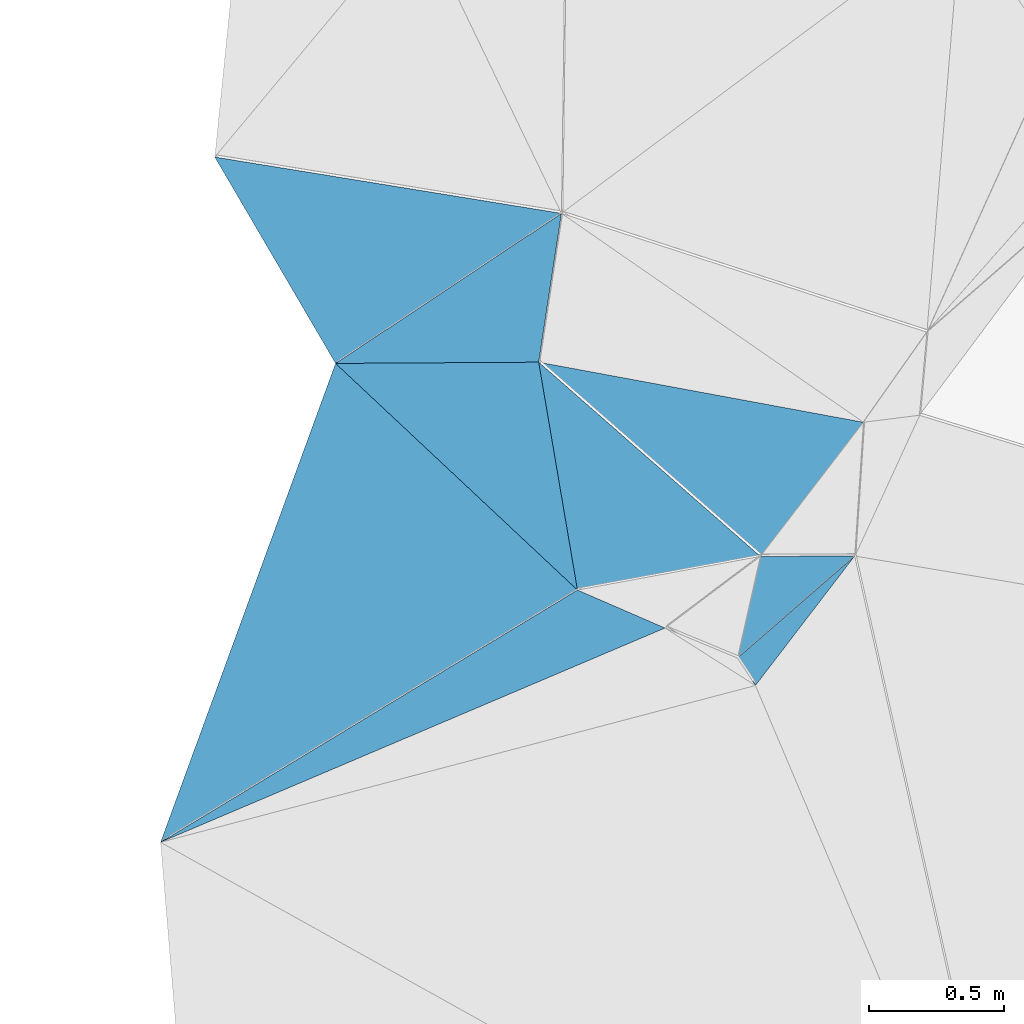
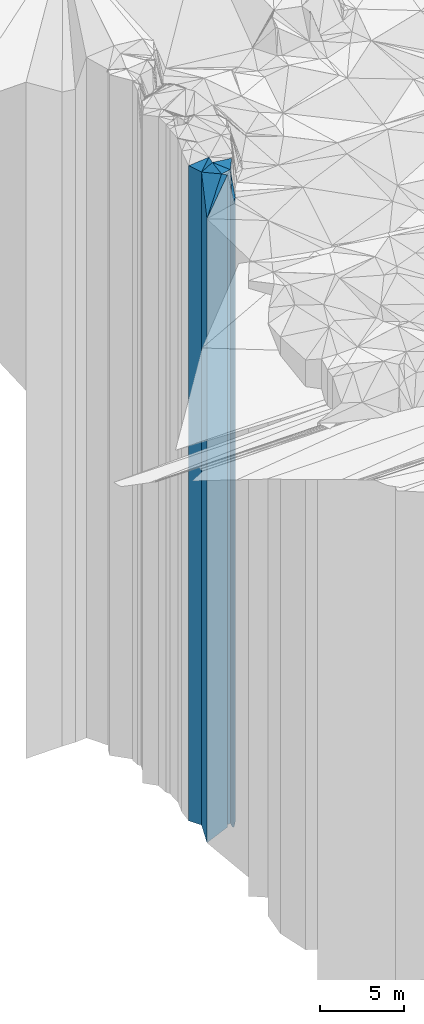
# One storey, part 219 of 275: 9 plates.
"""IFC2X3 building model written with IfcOpenShell, lengths in millimetres."""

from ifc_helpers import new_model, si_unit, frame, origin_with_axes, place, context, subcontext, project, spatial, faceted_brep, material, type_object, element, save


model = new_model("IFC2X3")

# Units and contexts
model_context = context("Model", 3, precision=1e-05, world=origin_with_axes())
body_context = subcontext(model_context, "Body", "Model", "MODEL_VIEW")
ifc_project = project(units=[si_unit("LENGTHUNIT", "METRE", prefix="MILLI"), si_unit("AREAUNIT", "SQUARE_METRE"), si_unit("VOLUMEUNIT", "CUBIC_METRE"), si_unit("MASSUNIT", "GRAM", prefix="KILO"), si_unit("TIMEUNIT", "SECOND"), si_unit("PLANEANGLEUNIT", "RADIAN"), si_unit("SOLIDANGLEUNIT", "STERADIAN"), si_unit("THERMODYNAMICTEMPERATUREUNIT", "DEGREE_CELSIUS"), si_unit("LUMINOUSINTENSITYUNIT", "LUMEN")], contexts=[model_context])

# Site, building, storey
site_placement = place(None, origin_with_axes())
site = spatial("IfcSite", under=ifc_project, at=site_placement, CompositionType="ELEMENT")
building_placement = place(site_placement, origin_with_axes())
building = spatial("IfcBuilding", under=site, at=building_placement, Name="Undefined", CompositionType="ELEMENT")
storey_placement = place(building_placement, origin_with_axes())
storey = spatial("IfcBuildingStorey", under=building, at=storey_placement, Name="Undefined", CompositionType="ELEMENT", Elevation=0.0)

# Plates
ifc_material = material()
plate_type_1 = type_object("IfcPlateType", PredefinedType="NOTDEFINED")
plate_1_placement = place(storey_placement, frame((-136499.498721579, 83557.2483316532, 30579.0), z_axis=(-0.793772278206384, 0.608215069158145, 0.0), x_axis=(0.608215069158141, 0.793772278206387, 0.0)))
element("IfcPlate", 1, at=plate_1_placement, inside=storey, type_object=plate_type_1, material=ifc_material, Name="00", context=body_context, shape_type="Brep", body=[
    faceted_brep([(-3.63797880709171e-12, -22751.0, -2.91038304567337e-11), (40.0561256408655, -22801.0, 114.871696472139), (40.0561256408655, 22751.0, 114.871696472139), (-3.63797880709171e-12, 22751.0, -2.91038304567337e-11), (604.15228271484, -22771.0, -3.43425199389458e-09), (604.15228271484, 22751.0, -3.43425199389458e-09)], [[[0, 1, 2, 3]], [[1, 4, 5, 2]], [[4, 0, 3, 5]], [[5, 3, 2]], [[4, 1, 0]]]),
])
plate_type_2 = type_object("IfcPlateType", PredefinedType="NOTDEFINED")
plate_2_placement = place(storey_placement, frame((-136481.326506082, 84035.4426128652, 30589.0), z_axis=(0.975458777497084, -0.220182136886477, 0.0), x_axis=(-0.220182136886474, -0.975458777497084, 0.0)))
element("IfcPlate", 2, at=plate_2_placement, inside=storey, type_object=plate_type_2, material=ifc_material, Name="00", context=body_context, shape_type="Brep", body=[
    faceted_brep([(7.27595761418343e-12, -24921.0, -2.91038304567337e-11), (-78.2372894287109, -22761.0, 340.409942626924), (-78.2372894287109, 22761.0, 340.409942626924), (7.27595761418343e-12, 22761.0, -2.91038304567337e-11), (386.005187988289, -22791.0, -4.36557456851006e-10), (386.005187988289, 22761.0, -4.36557456851006e-10)], [[[0, 1, 2, 3]], [[1, 4, 5, 2]], [[4, 0, 3, 5]], [[5, 3, 2]], [[4, 1, 0]]]),
])
plate_type_3 = type_object("IfcPlateType", PredefinedType="NOTDEFINED")
plate_3_placement = place(storey_placement, frame((-136099.624259448, 84532.2357236408, 31669.0), z_axis=(-0.182001300937891, -0.98329828966439, 0.0), x_axis=(-0.983298289664392, 0.182001300937881, 0.0)))
element("IfcPlate", 3, at=plate_3_placement, inside=storey, type_object=plate_type_3, material=ifc_material, Name="00", context=body_context, shape_type="Brep", body=[
    faceted_brep([(0.0, -24241.0, 0.0), (284.910186767578, -23841.0, 557.966125488281), (284.910186767578, 23841.0, 557.966125488281), (0.0, 23841.0, 0.0), (1223.19250488281, -24221.0, -1.13213900476694e-08), (1223.19250488281, 23841.0, -1.13213900476694e-08)], [[[0, 1, 2, 3]], [[1, 4, 5, 2]], [[4, 0, 3, 5]], [[5, 3, 2]], [[4, 1, 0]]]),
])
plate_type_4 = type_object("IfcPlateType", PredefinedType="NOTDEFINED")
plate_4_placement = place(storey_placement, frame((-138054.769147768, 84750.2000915425, 31639.0), z_axis=(-0.0061912420004811, 0.99998083407758, 0.0), x_axis=(0.99998083407758, 0.00619124200047754, 0.0)))
element("IfcPlate", 4, at=plate_4_placement, inside=storey, type_object=plate_type_4, material=ifc_material, Name="00", context=body_context, shape_type="Brep", body=[
    faceted_brep([(0.0, -23811.0, -1.45519152283669e-11), (840.11590576169, -24271.0, 550.640747070313), (840.11590576169, 23811.0, 550.640747070313), (0.0, 23811.0, -1.45519152283669e-11), (752.396179199219, -24251.0, 5.5297277867794e-10), (752.396179199219, 23811.0, 5.5297277867794e-10)], [[[0, 1, 2, 3]], [[1, 4, 5, 2]], [[4, 0, 3, 5]], [[5, 3, 2]], [[4, 1, 0]]]),
])
plate_type_5 = type_object("IfcPlateType", PredefinedType="NOTDEFINED")
plate_5_placement = place(storey_placement, frame((-138502.096254499, 85514.5942696885, 31639.0), z_axis=(0.863075081870162, 0.505075640924024, 0.0), x_axis=(0.505075640924028, -0.86307508187016, 0.0)))
element("IfcPlate", 5, at=plate_5_placement, inside=storey, type_object=plate_type_5, material=ifc_material, Name="00", context=body_context, shape_type="Brep", body=[
    faceted_brep([(-2.91038304567337e-11, -23971.0, -1.45519152283669e-11), (828.531311035127, -24271.0, 1002.86383056639), (828.531311035127, 23811.0, 1002.86383056639), (0.0, 23811.0, -1.45519152283669e-11), (885.663574218721, -23811.0, -8.57107806950808e-09), (885.663574218721, 23811.0, -8.57107806950808e-09)], [[[0, 1, 2, 3]], [[1, 4, 5, 2]], [[4, 0, 3, 5]], [[5, 3, 2]], [[4, 1, 0]]]),
])
plate_type_6 = type_object("IfcPlateType", PredefinedType="NOTDEFINED")
plate_6_placement = place(storey_placement, frame((-137158.801102415, 83910.8305294865, 31669.0), z_axis=(-0.1809014499919, 0.983501227955933, 0.0), x_axis=(0.983501227955934, 0.180901449991893, 0.0)))
element("IfcPlate", 6, at=plate_6_placement, inside=storey, type_object=plate_type_6, material=ifc_material, Name="00", context=body_context, shape_type="Brep", body=[
    faceted_brep([(-1.45519152283669e-11, -23841.0, -1.45519152283669e-11), (11.4685621261451, -24221.0, 856.07739257811), (11.4685621261451, 23841.0, 856.07739257811), (0.0, 23841.0, 0.0), (688.839599609375, -23841.0, 2.8085196390748e-09), (688.839599609375, 23841.0, 2.8085196390748e-09)], [[[0, 1, 2, 3]], [[1, 4, 5, 2]], [[4, 0, 3, 5]], [[5, 3, 2]], [[4, 1, 0]]]),
])
plate_type_7 = type_object("IfcPlateType", PredefinedType="NOTDEFINED")
plate_7_placement = place(storey_placement, frame((-138702.895086626, 82976.6069117577, 30589.0), z_axis=(-0.517656847008545, 0.855588329014119, 0.0), x_axis=(0.85558832901412, 0.517656847008543, 0.0)))
element("IfcPlate", 7, at=plate_7_placement, inside=storey, type_object=plate_type_7, material=ifc_material, Name="00", context=body_context, shape_type="Brep", body=[
    faceted_brep([(1.63709046319127e-11, -22761.0, -2.91038304567337e-11), (1472.64160156249, -24861.0, 1181.95874023438), (1472.64160156249, 22761.0, 1181.95874023438), (7.27595761418343e-12, 22761.0, -2.91038304567337e-11), (1804.71606445311, -24921.0, -3.11410985887051e-09), (1804.71606445311, 22761.0, -3.11410985887051e-09)], [[[0, 1, 2, 3]], [[1, 4, 5, 2]], [[4, 0, 3, 5]], [[5, 3, 2]], [[4, 1, 0]]]),
])
plate_type_8 = type_object("IfcPlateType", PredefinedType="NOTDEFINED")
plate_8_placement = place(storey_placement, frame((-138702.895086626, 82976.6069117577, 30589.0), z_axis=(-0.390837578018542, 0.920459661043655, 0.0), x_axis=(0.920459661043656, 0.390837578018539, 0.0)))
element("IfcPlate", 8, at=plate_8_placement, inside=storey, type_object=plate_type_8, material=ifc_material, Name="00", context=body_context, shape_type="Brep", body=[
    faceted_brep([(1.63709046319127e-11, -22761.0, -2.91038304567337e-11), (1786.40588378906, -24921.0, 256.42520141603), (1786.40588378906, 22761.0, 256.42520141603), (7.27595761418343e-12, 22761.0, -2.91038304567337e-11), (2030.22167968749, -24811.0, -1.83208612725139e-08), (2030.22167968749, 22761.0, -1.83208612725139e-08)], [[[0, 1, 2, 3]], [[1, 4, 5, 2]], [[4, 0, 3, 5]], [[5, 3, 2]], [[4, 1, 0]]]),
])
plate_type_9 = type_object("IfcPlateType", PredefinedType="NOTDEFINED")
plate_9_placement = place(storey_placement, frame((-137302.387395897, 84754.8583586035, 31639.0), z_axis=(0.0061912420004811, -0.99998083407758, 0.0), x_axis=(-0.999980834077579, -0.00619124200047778, 0.0)))
element("IfcPlate", 9, at=plate_9_placement, inside=storey, type_object=plate_type_9, material=ifc_material, Name="00", context=body_context, shape_type="Brep", body=[
    faceted_brep([(1.45519152283669e-11, -24251.0, 0.0), (-138.357955932617, -23871.0, 844.90063476564), (-138.357955932617, 23811.0, 844.90063476564), (0.0, 23811.0, -1.45519152283669e-11), (752.396179199219, -23811.0, 5.67524693906307e-10), (752.396179199219, 23811.0, 5.5297277867794e-10)], [[[0, 1, 2, 3]], [[1, 4, 5, 2]], [[4, 0, 3, 5]], [[5, 3, 2]], [[4, 1, 0]]]),
])

save(model, "model.ifc")
